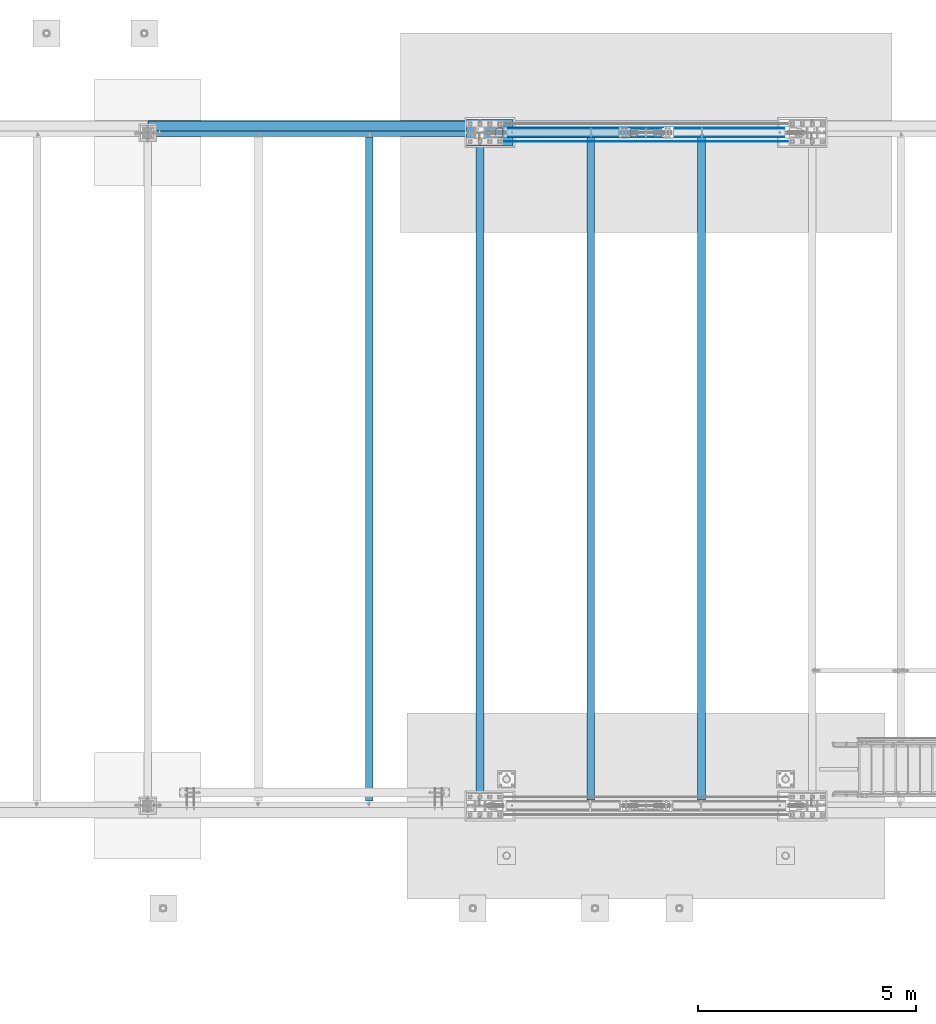
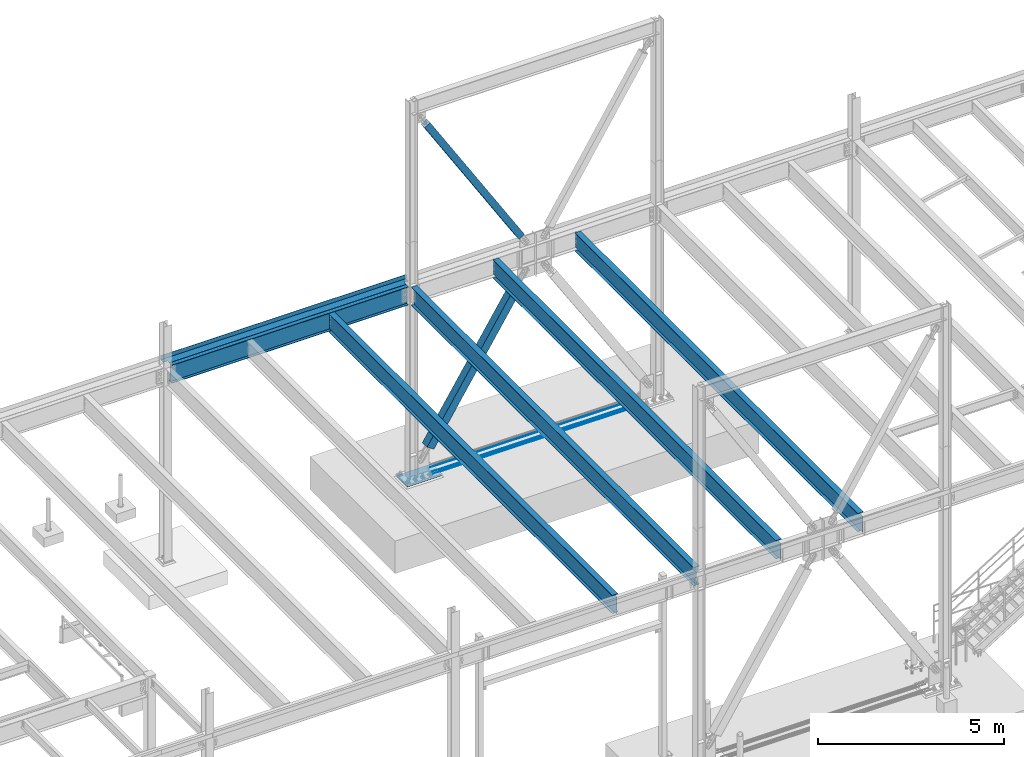
# One storey, part 1932 of 3843: 10 beams, 2 members, 11 elements without a shape of their own.
"""IFC2X3 building model written with IfcOpenShell, lengths in millimetres."""

from ifc_helpers import new_model, si_unit, frame, origin_with_axes, place, context, subcontext, project, spatial, faceted_brep, material, type_object, element, aggregate, save


model = new_model("IFC2X3")

# Units and contexts
model_context = context("Model", 3, precision=1e-05, world=origin_with_axes())
body_context = subcontext(model_context, "Body", "Model", "MODEL_VIEW")
ifc_project = project(units=[si_unit("LENGTHUNIT", "METRE", prefix="MILLI"), si_unit("AREAUNIT", "SQUARE_METRE"), si_unit("VOLUMEUNIT", "CUBIC_METRE"), si_unit("MASSUNIT", "GRAM", prefix="KILO"), si_unit("TIMEUNIT", "SECOND"), si_unit("PLANEANGLEUNIT", "RADIAN"), si_unit("SOLIDANGLEUNIT", "STERADIAN"), si_unit("THERMODYNAMICTEMPERATUREUNIT", "DEGREE_CELSIUS"), si_unit("LUMINOUSINTENSITYUNIT", "LUMEN")], contexts=[model_context])

# Site, building, storey
site_placement = place(None, origin_with_axes())
site = spatial("IfcSite", under=ifc_project, at=site_placement, CompositionType="ELEMENT")
building_placement = place(site_placement, origin_with_axes())
building = spatial("IfcBuilding", under=site, at=building_placement, Name="Undefined", CompositionType="ELEMENT")
storey_placement = place(building_placement, origin_with_axes())
storey = spatial("IfcBuildingStorey", under=building, at=storey_placement, Name="Undefined", CompositionType="ELEMENT", Elevation=0.0)

# Assembly, beam
assembly_1_placement = place(storey_placement, origin_with_axes())
assembly_1 = element("IfcElementAssembly", 1, at=assembly_1_placement, inside=storey, Name="REBAR", AssemblyPlace="NOTDEFINED", PredefinedType="RIGID_FRAME")
ifc_material_1 = material(Name="STEEL/A706-60")
beam_type_1 = type_object("IfcBeamType", Name="#10 REBAR", PredefinedType="NOTDEFINED")
beam_1_placement = place(assembly_1_placement, frame((23418.7999804674, 104355.9, 30132.3375), z_axis=(0.0, 0.0, 1.0), x_axis=(1.0, 0.0, 0.0)))
beam_1 = element("IfcBeam", 2, at=beam_1_placement, type_object=beam_type_1, material=ifc_material_1, Name="REBAR", ObjectType="#10 REBAR", context=body_context, shape_type="Brep", body=[
    faceted_brep([(0.0, -7.9375, 0.0), (0.0, -5.61266007566883, -5.61266007566883), (6502.48749999408, -5.61266007566883, -5.61266007566883), (6502.48749999408, -7.9375, 0.0), (0.0, 0.0, -7.9375), (6502.48749999408, 0.0, -7.9375), (0.0, 5.61266007566883, -5.61266007566883), (6502.48749999408, 5.61266007566883, -5.61266007566883), (0.0, 7.9375, 0.0), (6502.48749999408, 7.9375, 0.0), (0.0, 5.61266007566883, 5.61266007566883), (6502.48749999408, 5.61266007566883, 5.61266007566883), (0.0, 0.0, 7.9375), (6502.48749999408, 0.0, 7.9375), (0.0, -5.61266007566883, 5.61266007566883), (6502.48749999408, -5.61266007566883, 5.61266007566883)], [[[0, 1, 2, 3]], [[1, 4, 5, 2]], [[4, 6, 7, 5]], [[6, 8, 9, 7]], [[8, 10, 11, 9]], [[10, 12, 13, 11]], [[12, 14, 15, 13]], [[14, 0, 3, 15]], [[5, 7, 9, 11, 13, 15, 3, 2]], [[14, 12, 10, 8, 6, 4, 1, 0]]]),
])
aggregate(assembly_1, [beam_1])

assembly_2_placement = place(storey_placement, origin_with_axes())
assembly_2 = element("IfcElementAssembly", 3, at=assembly_2_placement, inside=storey, Name="REBAR", AssemblyPlace="NOTDEFINED", PredefinedType="RIGID_FRAME")
beam_2_placement = place(assembly_2_placement, frame((23418.7999804674, 104457.5, 30132.3375), z_axis=(0.0, 0.0, 1.0), x_axis=(1.0, 0.0, 0.0)))
beam_2 = element("IfcBeam", 4, at=beam_2_placement, type_object=beam_type_1, material=ifc_material_1, Name="REBAR", ObjectType="#10 REBAR", context=body_context, shape_type="Brep", body=[
    faceted_brep([(0.0, -7.9375, 0.0), (0.0, -5.61266007566883, -5.61266007566883), (6502.48749999408, -5.61266007566883, -5.61266007566883), (6502.48749999408, -7.9375, 0.0), (0.0, 0.0, -7.9375), (6502.48749999408, 0.0, -7.9375), (0.0, 5.61266007566883, -5.61266007566883), (6502.48749999408, 5.61266007566883, -5.61266007566883), (0.0, 7.9375, 0.0), (6502.48749999408, 7.9375, 0.0), (0.0, 5.61266007566883, 5.61266007566883), (6502.48749999408, 5.61266007566883, 5.61266007566883), (0.0, 0.0, 7.9375), (6502.48749999408, 0.0, 7.9375), (0.0, -5.61266007566883, 5.61266007566883), (6502.48749999408, -5.61266007566883, 5.61266007566883)], [[[0, 1, 2, 3]], [[1, 4, 5, 2]], [[4, 6, 7, 5]], [[6, 8, 9, 7]], [[8, 10, 11, 9]], [[10, 12, 13, 11]], [[12, 14, 15, 13]], [[14, 0, 3, 15]], [[5, 7, 9, 11, 13, 15, 3, 2]], [[14, 12, 10, 8, 6, 4, 1, 0]]]),
])
aggregate(assembly_2, [beam_2])

assembly_3_placement = place(storey_placement, origin_with_axes())
assembly_3 = element("IfcElementAssembly", 5, at=assembly_3_placement, inside=storey, Name="REBAR", AssemblyPlace="NOTDEFINED", PredefinedType="RIGID_FRAME")
beam_3_placement = place(assembly_3_placement, frame((23418.7999804674, 104660.7, 30132.3375), z_axis=(0.0, 0.0, 1.0), x_axis=(1.0, 0.0, 0.0)))
beam_3 = element("IfcBeam", 6, at=beam_3_placement, type_object=beam_type_1, material=ifc_material_1, Name="REBAR", ObjectType="#10 REBAR", context=body_context, shape_type="Brep", body=[
    faceted_brep([(0.0, -7.9375, 0.0), (0.0, -5.61266007566883, -5.61266007566883), (6502.48749999408, -5.61266007566883, -5.61266007566883), (6502.48749999408, -7.9375, 0.0), (0.0, 0.0, -7.9375), (6502.48749999408, 0.0, -7.9375), (0.0, 5.61266007566883, -5.61266007566883), (6502.48749999408, 5.61266007566883, -5.61266007566883), (0.0, 7.9375, 0.0), (6502.48749999408, 7.9375, 0.0), (0.0, 5.61266007566883, 5.61266007566883), (6502.48749999408, 5.61266007566883, 5.61266007566883), (0.0, 0.0, 7.9375), (6502.48749999408, 0.0, 7.9375), (0.0, -5.61266007566883, 5.61266007566883), (6502.48749999408, -5.61266007566883, 5.61266007566883)], [[[0, 1, 2, 3]], [[1, 4, 5, 2]], [[4, 6, 7, 5]], [[6, 8, 9, 7]], [[8, 10, 11, 9]], [[10, 12, 13, 11]], [[12, 14, 15, 13]], [[14, 0, 3, 15]], [[5, 7, 9, 11, 13, 15, 3, 2]], [[14, 12, 10, 8, 6, 4, 1, 0]]]),
])
aggregate(assembly_3, [beam_3])

# Assembly, member
assembly_4_placement = place(storey_placement, origin_with_axes())
assembly_4 = element("IfcElementAssembly", 7, at=assembly_4_placement, inside=storey, Name="None", AssemblyPlace="NOTDEFINED", PredefinedType="RIGID_FRAME")
ifc_material_2 = material(Name="STEEL/A992")
member_type_1 = type_object("IfcMemberType", Name="HSS8X8X3/16", PredefinedType="NOTDEFINED")
member_1_placement = place(assembly_4_placement, frame((26220.958940922, 104559.1, 36853.7019844734), z_axis=(0.0, 1.0, 0.0), x_axis=(-0.529701323009257, 0.0, 0.848184242014813)))
member_1 = element("IfcMember", 8, at=member_1_placement, type_object=member_type_1, material=ifc_material_2, Name="None", ObjectType="HSS8X8X3/16", context=body_context, shape_type="Brep", body=[
    faceted_brep([(2.03726813197136e-10, 96.8375000003298, -96.8374999999942), (-2.18278728425503e-10, -96.837500000317, -96.8374999999942), (5518.14999998289, -96.8375000060396, -96.8374999999942), (5518.14999998332, 96.8374999946072, -96.8374999999942), (-2.18278728425503e-10, -96.837500000317, 96.8374999999942), (5518.14999998289, -96.8375000060396, 96.8374999999942), (2.03726813197136e-10, 96.8375000003298, 96.8374999999942), (5518.14999998332, 96.8374999946072, 96.8374999999942), (2.18278728425503e-10, 101.600000000345, -101.600000000006), (2.18278728425503e-10, 101.600000000345, 101.600000000006), (5518.14999998333, 101.599999994626, 101.600000000006), (5518.14999998333, 101.599999994626, -101.600000000006), (-2.25554686039686e-10, -101.600000000329, 101.600000000006), (5518.14999998289, -101.600000006059, 101.600000000006), (-2.25554686039686e-10, -101.600000000329, -101.600000000006), (5518.14999998289, -101.600000006059, -101.600000000006)], [[[0, 1, 2, 3]], [[1, 4, 5, 2]], [[4, 6, 7, 5]], [[6, 0, 3, 7]], [[8, 9, 10, 11]], [[9, 12, 13, 10]], [[12, 14, 15, 13]], [[14, 8, 11, 15]], [[13, 15, 11, 10], [5, 7, 3, 2]], [[14, 12, 9, 8], [6, 4, 1, 0]]]),
])
aggregate(assembly_4, [member_1])

assembly_5_placement = place(storey_placement, origin_with_axes())
assembly_5 = element("IfcElementAssembly", 9, at=assembly_5_placement, inside=storey, Name="None", AssemblyPlace="NOTDEFINED", PredefinedType="RIGID_FRAME")
member_type_2 = type_object("IfcMemberType", Name="HSS10X10X1/4", PredefinedType="NOTDEFINED")
member_2_placement = place(assembly_5_placement, frame((23376.770306377, 104559.1, 30939.605175297), z_axis=(0.0, -1.0, 0.0), x_axis=(0.535402318785024, 0.0, 0.844597156660866)))
member_2 = element("IfcMember", 10, at=member_2_placement, type_object=member_type_2, material=ifc_material_2, Name="None", ObjectType="HSS10X10X1/4", context=body_context, shape_type="Brep", body=[
    faceted_brep([(2.00088834390044e-10, 120.650000000089, -120.649999999994), (-2.03726813197136e-10, -120.650000000081, -120.649999999994), (5175.25000000853, -120.650000001752, -120.649999999994), (5175.25000000861, 120.649999998298, -120.649999999994), (-2.03726813197136e-10, -120.650000000081, 120.649999999994), (5175.25000000853, -120.650000001752, 120.649999999994), (2.00088834390044e-10, 120.650000000089, 120.649999999994), (5175.25000000861, 120.649999998298, 120.649999999994), (2.16459739021957e-10, 127.000000000087, -127.0), (2.16459739021957e-10, 127.000000000087, 127.0), (5175.25000000861, 126.9999999983, 127.0), (5175.25000000861, 126.9999999983, -127.0), (-2.14640749618411e-10, -127.00000000008, 127.0), (5175.25000000852, -127.000000001754, 127.0), (-2.14640749618411e-10, -127.00000000008, -127.0), (5175.25000000852, -127.000000001754, -127.0)], [[[0, 1, 2, 3]], [[1, 4, 5, 2]], [[4, 6, 7, 5]], [[6, 0, 3, 7]], [[8, 9, 10, 11]], [[9, 12, 13, 10]], [[12, 14, 15, 13]], [[14, 8, 11, 15]], [[13, 15, 11, 10], [5, 7, 3, 2]], [[14, 12, 9, 8], [6, 4, 1, 0]]]),
])
aggregate(assembly_5, [member_2])

# Assembly, beam
assembly_6_placement = place(storey_placement, origin_with_axes())
assembly_6 = element("IfcElementAssembly", 11, at=assembly_6_placement, inside=storey, Name="BEAM", AssemblyPlace="NOTDEFINED", PredefinedType="RIGID_FRAME")
ifc_material_3 = material(Name="STEEL/A36")
beam_type_2 = type_object("IfcBeamType", PredefinedType="NOTDEFINED")
beam_4_placement = place(assembly_6_placement, frame((19050.0, 104597.2, 36439.475), z_axis=(-1.0, 0.0, 0.0), x_axis=(0.0, 1.0, 0.0)))
beam_4 = element("IfcBeam", 12, at=beam_4_placement, type_object=beam_type_2, material=ifc_material_3, Name="BENT_PLATE", context=body_context, shape_type="Brep", body=[
    faceted_brep([(101.599996948149, -3.17499999999563, 3670.30000000001), (101.599996948149, 3.17500000000291, 3670.30000000001), (0.0, 3.17500000000291, 3670.30000000001), (0.0, -3.17500000000291, 3670.30000000001), (101.599996948149, -3.17499999999563, 3806.825), (101.599996948149, 3.17500000000291, 3806.825), (0.0, -3.17500000000291, -3667.12500305074), (0.0, 3.17500000000291, -3667.12500305074), (103.187506103422, 3.17500000000291, -3667.12500305074), (103.187506103422, -3.17499999999563, -3667.12500305074), (103.187506103422, 3.17500000000291, -3806.825), (103.187506103422, -3.17499999999563, -3806.825), (241.300003051641, 3.17500000001019, -3806.825), (241.300003051685, -136.524996948348, -3806.825), (234.950003051679, -136.524996948348, -3806.825), (234.950003051636, -3.17499999999563, -3806.825), (241.300003051641, 3.17500000001019, 3806.825), (241.300003051685, -136.524996948348, 3806.825), (234.950003051679, -136.524996948348, 3806.825), (234.950003051636, -3.17499999999563, 3806.825)], [[[0, 1, 2, 3]], [[4, 5, 1, 0]], [[6, 7, 8, 9]], [[9, 8, 10, 11]], [[12, 13, 14, 15, 11, 10]], [[12, 16, 17, 13]], [[18, 14, 13, 17]], [[19, 15, 14, 18]], [[3, 6, 9, 11, 15, 19, 4, 0]], [[7, 6, 3, 2]], [[16, 12, 10, 8, 7, 2, 1, 5]], [[19, 18, 17, 16, 5, 4]]]),
])

assembly_7_placement = place(storey_placement, origin_with_axes())
assembly_7 = element("IfcElementAssembly", 13, at=assembly_7_placement, inside=storey, Name="BEAM", AssemblyPlace="NOTDEFINED", PredefinedType="RIGID_FRAME")
beam_type_3 = type_object("IfcBeamType", Name="W24X55", PredefinedType="NOTDEFINED")
beam_5_placement = place(assembly_7_placement, frame((20320.0, 89115.9, 36136.2625), z_axis=(0.0, 0.0, 1.0), x_axis=(0.0, 1.0, 0.0)))
beam_5 = element("IfcBeam", 14, at=beam_5_placement, type_object=beam_type_3, material=ifc_material_2, Name="BEAM", ObjectType="W24X55", context=body_context, shape_type="Brep", body=[
    faceted_brep([(17.4624999999942, -4.76250000000073, -274.637500000004), (17.4624999999942, 4.76250000000073, -274.637500000004), (93.6625001907232, 4.76250000000073, -274.637500000004), (93.6625001907232, -4.76250000000073, -274.637500000004), (98.5225797087624, 4.76250000000073, -275.604229922596), (98.5225797087624, -4.76250000000073, -275.604229922596), (102.642756176923, 4.76250000000073, -278.357243823069), (102.642756176923, -4.76250000000073, -278.357243823069), (105.395770077404, 4.76250000000073, -282.477420291223), (105.395770077404, -4.76250000000073, -282.477420291223), (106.362499999988, 4.76250000000073, -287.337500000001), (106.362499999988, -4.76250000000073, -287.337500000001), (106.362499999988, -88.8999999999996, -287.33749980927), (106.362499999988, 88.8999999999996, -287.337500000001), (106.362499999988, 88.8999999999996, -300.037499999999), (106.362499999988, -88.8999999999996, -300.037499809485), (15341.6, -88.8999999999996, -300.037499999999), (15341.6, 88.8999999999996, -300.037499999999), (15341.6, 88.8999999999996, -287.597499809272), (15341.6, -88.8999999999996, -287.597499809272), (15341.6, 88.8999999999996, 287.337500000001), (15341.6, 4.76250000000073, 287.337500000001), (106.362499999988, 4.76250000000073, 287.337500000001), (106.362499999988, 88.8999999999996, 287.337500000001), (93.6625001907232, -4.76250000000073, 274.637499999997), (93.6625001907232, 4.76250000000073, 274.637499999997), (17.4624999999942, 4.76250000000073, 274.637499999997), (17.4624999999942, -4.76250000000073, 274.637499999997), (98.5225797087624, -4.76250000000073, 275.604229922588), (98.5225797087624, 4.76250000000073, 275.604229922588), (102.642756176923, -4.76250000000073, 278.357243823062), (102.642756176923, 4.76250000000073, 278.357243823062), (105.395770077404, -4.76250000000073, 282.477420291216), (105.395770077404, 4.76250000000073, 282.477420291216), (106.362499999988, -4.76250000000073, 287.337500000001), (15341.6, -88.8999999999996, 300.037499999999), (15341.6, 88.8999999999996, 300.037499999999), (106.362499999988, 88.8999999999996, 300.037499999999), (106.362499999988, -88.8999999999996, 300.037499809485), (15341.6, -88.8999999999996, 287.337500000001), (106.362499999988, -88.8999999999996, 287.337500000001), (15341.6, -4.76250000000073, 287.337500000001), (15341.6, -4.76250000000073, 287.07749980926), (15341.6, 4.76250000000073, 287.07749980926), (15342.5667299226, -4.76250000000073, 282.217420291214), (15342.5667299226, 4.76250000000073, 282.217420291214), (15345.3197438231, -4.76250000000073, 278.09724382306), (15345.3197438231, 4.76250000000073, 278.09724382306), (15349.4399202912, -4.76250000000073, 275.344229922586), (15349.4399202912, 4.76250000000073, 275.344229922586), (15354.2999998093, -4.76250000000073, 274.377499999995), (15354.2999998093, 4.76250000000073, 274.377499999995), (15425.7375, -4.76250000000073, 274.377499999995), (15425.7375, 4.76250000000073, 274.377499999995), (15425.7375, -4.76250000000073, -274.897500000006), (15425.7375, 4.76250000000073, -274.897500000006), (15354.2999998093, -4.76250000000073, -274.897500000006), (15354.2999998093, 4.76250000000073, -274.897500000006), (15349.4399202912, -4.76250000000073, -275.864229922598), (15349.4399202912, 4.76250000000073, -275.864229922598), (15345.3197438231, -4.76250000000073, -278.617243823071), (15345.3197438231, 4.76250000000073, -278.617243823071), (15342.5667299226, -4.76250000000073, -282.737420291225), (15342.5667299226, 4.76250000000073, -282.737420291225), (15341.6517171776, -4.76250000000073, -287.337500000001), (15341.6517171776, -88.8999999999996, -287.337500000001), (15341.6517171776, 88.8999999999996, -287.337500000001), (15341.6517171776, 4.76250000000073, -287.337500000001), (17.4624999999942, 4.76250000000073, -197.262499999997), (17.4624999999942, 4.76250000000073, 261.9375)], [[[0, 1, 2, 3]], [[3, 2, 4, 5]], [[5, 4, 6, 7]], [[7, 6, 8, 9]], [[9, 8, 10, 11]], [[12, 11, 10, 13, 14, 15]], [[16, 17, 18, 19]], [[20, 21, 22, 23]], [[24, 25, 26, 27]], [[28, 29, 25, 24]], [[30, 31, 29, 28]], [[32, 33, 31, 30]], [[34, 22, 33, 32]], [[35, 36, 37, 38]], [[39, 35, 38, 40]], [[41, 39, 40, 34]], [[38, 37, 23, 22, 34, 40]], [[36, 20, 23, 37]], [[35, 39, 41, 42, 43, 21, 20, 36]], [[44, 45, 43, 42]], [[46, 47, 45, 44]], [[48, 49, 47, 46]], [[50, 51, 49, 48]], [[52, 53, 51, 50]], [[53, 52, 54, 55]], [[54, 56, 57, 55]], [[58, 59, 57, 56]], [[60, 61, 59, 58]], [[62, 63, 61, 60]], [[64, 65, 19, 18, 66, 67, 63, 62]], [[16, 19, 65, 12, 15]], [[17, 16, 15, 14]], [[66, 18, 17, 14, 13]], [[67, 66, 13, 10]], [[6, 4, 2, 1, 68, 69, 26, 25, 29, 31, 33, 22, 21, 43, 45, 47, 49, 51, 53, 55, 57, 59, 61, 63, 67, 10, 8]], [[27, 26, 69, 68, 1, 0]], [[64, 62, 60, 58, 56, 54, 52, 50, 48, 46, 44, 42, 41, 34, 32, 30, 28, 24, 27, 0, 3, 5, 7, 9, 11]], [[65, 64, 11, 12]]]),
])
aggregate(assembly_7, [beam_5])

# Beam
beam_6_placement = place(assembly_6_placement, frame((15240.0, 104559.1, 36136.2625), z_axis=(0.0, 0.0, 1.0), x_axis=(1.0, 0.0, 0.0)))
beam_6 = element("IfcBeam", 15, at=beam_6_placement, type_object=beam_type_3, material=ifc_material_2, Name="BEAM", ObjectType="W24X55", context=body_context, shape_type="Brep", body=[
    faceted_brep([(139.699999999997, -88.8999999999996, -300.037499999999), (139.699999999997, 88.8999999999996, -300.037499999999), (7477.125, 88.8999999999942, -300.037499999999), (7477.125, -88.8999999999942, -300.037499999999), (139.699999999997, -88.8999999999996, -287.337500000001), (139.699999999997, -4.76250000000073, -287.337500000001), (139.7, -4.76249999999709, -208.702493896482), (139.7, -4.76249999999709, 262.677499999998), (139.699999999997, -4.76250000000073, 287.337500000001), (139.699999999997, -88.8999999999996, 287.337500000001), (139.699999999997, -88.8999999999996, 300.037499999999), (139.699999999997, 88.8999999999996, 300.037499999999), (139.699999999997, 88.8999999999996, 287.337500000001), (139.699999999997, 4.76250000000073, 287.337500000001), (139.699999999997, 4.76250000000073, -287.337500000001), (139.699999999997, 88.8999999999996, -287.337500000001), (7477.125, -88.8999999999942, -287.337500000001), (7477.125, -4.76249999999709, -287.337500000001), (7477.125, -4.76249999999709, 287.337500000001), (7477.125, -88.8999999999942, 287.337500000001), (7477.125, -88.8999999999942, 300.037499999999), (7477.125, 88.8999999999942, 300.037499999999), (7477.125, 88.8999999999942, 287.337500000001), (7477.125, 4.76249999999709, 287.337500000001), (7477.125, 4.76249999999709, -287.337500000001), (7477.125, 88.8999999999942, -287.337500000001)], [[[0, 1, 2, 3]], [[0, 4, 5, 6, 7, 8, 9, 10, 11, 12, 13, 14, 15, 1]], [[5, 4, 16, 17]], [[8, 7, 6, 5, 17, 18]], [[9, 8, 18, 19]], [[10, 9, 19, 20]], [[11, 10, 20, 21]], [[12, 11, 21, 22]], [[13, 12, 22, 23]], [[14, 13, 23, 24]], [[15, 14, 24, 25]], [[1, 15, 25, 2]], [[24, 23, 22, 21, 20, 19, 18, 17, 16, 3, 2, 25]], [[4, 0, 3, 16]]]),
])

aggregate(assembly_6, [beam_4, beam_6])

# Assembly, beam
assembly_8_placement = place(storey_placement, origin_with_axes())
assembly_8 = element("IfcElementAssembly", 16, at=assembly_8_placement, inside=storey, Name="BEAM", AssemblyPlace="NOTDEFINED", PredefinedType="RIGID_FRAME")
beam_7_placement = place(assembly_8_placement, frame((25400.0, 89115.9, 36136.2625), z_axis=(0.0, 0.0, 1.0), x_axis=(0.0, 1.0, 0.0)))
beam_7 = element("IfcBeam", 17, at=beam_7_placement, type_object=beam_type_3, material=ifc_material_2, Name="BEAM", ObjectType="W24X55", context=body_context, shape_type="Brep", body=[
    faceted_brep([(18.2562500000058, -4.76250000000073, -274.637499999997), (18.2562500000058, 4.76250000000073, -274.637499999997), (119.856250190758, 4.76250000000073, -274.637499999997), (119.856250190758, -4.76250000000073, -274.637499999997), (124.716329708797, 4.76250000000073, -275.604229922588), (124.716329708797, -4.76250000000073, -275.604229922588), (128.836506176958, 4.76250000000073, -278.357243823062), (128.836506176958, -4.76250000000073, -278.357243823062), (131.589520077439, 4.76250000000073, -282.477420291216), (131.589520077439, -4.76250000000073, -282.477420291216), (132.556250000023, 4.76250000000073, -287.337500000001), (132.556250000023, -4.76250000000073, -287.337500000001), (132.556250000023, -88.9000000000015, -287.337499809262), (132.556250000023, 88.9000000000015, -287.337500000001), (132.556250000023, 88.9000000000015, -300.037499999999), (132.556250000023, -88.9000000000015, -300.037499999999), (15315.40625, 88.9000000000015, 287.337500000001), (15315.40625, 4.76250000000073, 287.337500000001), (132.556250000023, 4.76250000000073, 287.337500000001), (132.556250000023, 88.9000000000015, 287.337500000001), (119.856250190758, -4.76250000000073, 261.9375), (119.856250190758, 4.76250000000073, 261.9375), (18.2562500000058, 4.76250000000073, 261.9375), (18.2562500000058, -4.76250000000073, 261.9375), (124.716329708797, -4.76250000000073, 262.904229922591), (124.716329708797, 4.76250000000073, 262.904229922591), (128.836506176958, -4.76250000000073, 265.657243823065), (128.836506176958, 4.76250000000073, 265.657243823065), (131.589520077439, -4.76250000000073, 269.777420291219), (131.589520077439, 4.76250000000073, 269.777420291219), (132.556250000023, -4.76250000000073, 274.637499809265), (132.556250000023, 4.76250000000073, 274.637499809265), (15315.40625, -88.9000000000015, 300.037499999999), (15315.40625, 88.9000000000015, 300.037499999999), (132.556250000023, 88.9000000000015, 300.037499999999), (132.556250000023, -88.9000000000015, 300.037499999999), (15315.40625, -88.9000000000015, 287.337500000001), (132.556250000023, -88.9000000000015, 287.337500000001), (15315.40625, -4.76250000000073, 287.337500000001), (132.556250000023, -4.76250000000073, 287.337500000001), (15315.40625, -4.76250000000073, 274.637499809265), (15315.40625, 4.76250000000073, 274.637499809265), (15316.3729799226, -4.76250000000073, 269.777420291219), (15316.3729799226, 4.76250000000073, 269.777420291219), (15319.1259938231, -4.76250000000073, 265.657243823065), (15319.1259938231, 4.76250000000073, 265.657243823065), (15323.2461702912, -4.76250000000073, 262.904229922591), (15323.2461702912, 4.76250000000073, 262.904229922591), (15328.1062498093, -4.76250000000073, 261.9375), (15328.1062498093, 4.76250000000073, 261.9375), (15424.94375, -4.76250000000073, 261.9375), (15424.94375, 4.76250000000073, 261.9375), (15424.94375, -4.76250000000073, -274.637499999997), (15424.94375, 4.76250000000073, -274.637499999997), (15328.1062498093, -4.76250000000073, -274.637499999997), (15328.1062498093, 4.76250000000073, -274.637499999997), (15323.2461702912, -4.76250000000073, -275.604229922581), (15323.2461702912, 4.76250000000073, -275.604229922581), (15319.1259938231, -4.76250000000073, -278.357243823062), (15319.1259938231, 4.76250000000073, -278.357243823062), (15316.3729799226, -4.76250000000073, -282.477420291216), (15316.3729799226, 4.76250000000073, -282.477420291216), (15315.40625, -4.76250000000073, -287.337500000001), (15315.40625, 4.76250000000073, -287.337500000001), (15315.40625, -88.9000000000015, -287.337500000001), (15315.40625, -88.9000000000015, -300.037499999999), (15315.40625, 88.9000000000015, -300.037499999999), (15315.40625, 88.9000000000015, -287.337500000001)], [[[0, 1, 2, 3]], [[3, 2, 4, 5]], [[5, 4, 6, 7]], [[7, 6, 8, 9]], [[9, 8, 10, 11]], [[12, 11, 10, 13, 14, 15]], [[16, 17, 18, 19]], [[20, 21, 22, 23]], [[24, 25, 21, 20]], [[26, 27, 25, 24]], [[28, 29, 27, 26]], [[30, 31, 29, 28]], [[32, 33, 34, 35]], [[36, 32, 35, 37]], [[38, 36, 37, 39]], [[35, 34, 19, 18, 31, 30, 39, 37]], [[33, 16, 19, 34]], [[32, 36, 38, 40, 41, 17, 16, 33]], [[42, 43, 41, 40]], [[44, 45, 43, 42]], [[46, 47, 45, 44]], [[48, 49, 47, 46]], [[50, 51, 49, 48]], [[51, 50, 52, 53]], [[52, 54, 55, 53]], [[56, 57, 55, 54]], [[58, 59, 57, 56]], [[60, 61, 59, 58]], [[62, 63, 61, 60]], [[64, 65, 66, 67, 63, 62]], [[65, 64, 12, 15]], [[66, 65, 15, 14]], [[67, 66, 14, 13]], [[63, 67, 13, 10]], [[6, 4, 2, 1, 22, 21, 25, 27, 29, 31, 18, 17, 41, 43, 45, 47, 49, 51, 53, 55, 57, 59, 61, 63, 10, 8]], [[23, 22, 1, 0]], [[62, 60, 58, 56, 54, 52, 50, 48, 46, 44, 42, 40, 38, 39, 30, 28, 26, 24, 20, 23, 0, 3, 5, 7, 9, 11]], [[64, 62, 11, 12]]]),
])
aggregate(assembly_8, [beam_7])

assembly_9_placement = place(storey_placement, origin_with_axes())
assembly_9 = element("IfcElementAssembly", 18, at=assembly_9_placement, inside=storey, Name="BEAM", AssemblyPlace="NOTDEFINED", PredefinedType="RIGID_FRAME")
beam_8_placement = place(assembly_9_placement, frame((27940.0, 89115.9, 36136.2625), z_axis=(0.0, 0.0, 1.0), x_axis=(0.0, 1.0, 0.0)))
beam_8 = element("IfcBeam", 19, at=beam_8_placement, type_object=beam_type_3, material=ifc_material_2, Name="BEAM", ObjectType="W24X55", context=body_context, shape_type="Brep", body=[
    faceted_brep([(18.2562500000058, -4.76250000000073, -274.637499999997), (18.2562500000058, 4.76250000000073, -274.637499999997), (119.856250190758, 4.76250000000073, -274.637499999997), (119.856250190758, -4.76250000000073, -274.637499999997), (124.716329708797, 4.76250000000073, -275.604229922588), (124.716329708797, -4.76250000000073, -275.604229922588), (128.836506176958, 4.76250000000073, -278.357243823062), (128.836506176958, -4.76250000000073, -278.357243823062), (131.589520077439, 4.76250000000073, -282.477420291216), (131.589520077439, -4.76250000000073, -282.477420291216), (132.556250000023, 4.76250000000073, -287.337500000001), (132.556250000023, -4.76250000000073, -287.337500000001), (132.556250000023, -88.9000000000015, -287.337499809262), (132.556250000023, 88.9000000000015, -287.337500000001), (132.556250000023, 88.9000000000015, -300.037499999999), (132.556250000023, -88.9000000000015, -300.037499999999), (15315.40625, 88.9000000000015, 287.337500000001), (15315.40625, 4.76250000000073, 287.337500000001), (132.556250000023, 4.76250000000073, 287.337500000001), (132.556250000023, 88.9000000000015, 287.337500000001), (119.856250190758, -4.76250000000073, 261.9375), (119.856250190758, 4.76250000000073, 261.9375), (18.2562500000058, 4.76250000000073, 261.9375), (18.2562500000058, -4.76250000000073, 261.9375), (124.716329708797, -4.76250000000073, 262.904229922591), (124.716329708797, 4.76250000000073, 262.904229922591), (128.836506176958, -4.76250000000073, 265.657243823065), (128.836506176958, 4.76250000000073, 265.657243823065), (131.589520077439, -4.76250000000073, 269.777420291219), (131.589520077439, 4.76250000000073, 269.777420291219), (132.556250000023, -4.76250000000073, 274.637499809265), (132.556250000023, 4.76250000000073, 274.637499809265), (15315.40625, -88.9000000000015, 300.037499999999), (15315.40625, 88.9000000000015, 300.037499999999), (132.556250000023, 88.9000000000015, 300.037499999999), (132.556250000023, -88.9000000000015, 300.037499999999), (15315.40625, -88.9000000000015, 287.337500000001), (132.556250000023, -88.9000000000015, 287.337500000001), (15315.40625, -4.76250000000073, 287.337500000001), (132.556250000023, -4.76250000000073, 287.337500000001), (15315.40625, -4.76250000000073, 274.637499809265), (15315.40625, 4.76250000000073, 274.637499809265), (15316.3729799226, -4.76250000000073, 269.777420291219), (15316.3729799226, 4.76250000000073, 269.777420291219), (15319.1259938231, -4.76250000000073, 265.657243823065), (15319.1259938231, 4.76250000000073, 265.657243823065), (15323.2461702912, -4.76250000000073, 262.904229922591), (15323.2461702912, 4.76250000000073, 262.904229922591), (15328.1062498093, -4.76250000000073, 261.9375), (15328.1062498093, 4.76250000000073, 261.9375), (15424.94375, -4.76250000000073, 261.9375), (15424.94375, 4.76250000000073, 261.9375), (15424.94375, -4.76250000000073, -274.637499999997), (15424.94375, 4.76250000000073, -274.637499999997), (15328.1062498093, -4.76250000000073, -274.637499999997), (15328.1062498093, 4.76250000000073, -274.637499999997), (15323.2461702912, -4.76250000000073, -275.604229922581), (15323.2461702912, 4.76250000000073, -275.604229922581), (15319.1259938231, -4.76250000000073, -278.357243823062), (15319.1259938231, 4.76250000000073, -278.357243823062), (15316.3729799226, -4.76250000000073, -282.477420291216), (15316.3729799226, 4.76250000000073, -282.477420291216), (15315.40625, -4.76250000000073, -287.337500000001), (15315.40625, 4.76250000000073, -287.337500000001), (15315.40625, -88.9000000000015, -287.337500000001), (15315.40625, -88.9000000000015, -300.037499999999), (15315.40625, 88.9000000000015, -300.037499999999), (15315.40625, 88.9000000000015, -287.337500000001)], [[[0, 1, 2, 3]], [[3, 2, 4, 5]], [[5, 4, 6, 7]], [[7, 6, 8, 9]], [[9, 8, 10, 11]], [[12, 11, 10, 13, 14, 15]], [[16, 17, 18, 19]], [[20, 21, 22, 23]], [[24, 25, 21, 20]], [[26, 27, 25, 24]], [[28, 29, 27, 26]], [[30, 31, 29, 28]], [[32, 33, 34, 35]], [[36, 32, 35, 37]], [[38, 36, 37, 39]], [[35, 34, 19, 18, 31, 30, 39, 37]], [[33, 16, 19, 34]], [[32, 36, 38, 40, 41, 17, 16, 33]], [[42, 43, 41, 40]], [[44, 45, 43, 42]], [[46, 47, 45, 44]], [[48, 49, 47, 46]], [[50, 51, 49, 48]], [[51, 50, 52, 53]], [[52, 54, 55, 53]], [[56, 57, 55, 54]], [[58, 59, 57, 56]], [[60, 61, 59, 58]], [[62, 63, 61, 60]], [[64, 65, 66, 67, 63, 62]], [[65, 64, 12, 15]], [[66, 65, 15, 14]], [[67, 66, 14, 13]], [[63, 67, 13, 10]], [[6, 4, 2, 1, 22, 21, 25, 27, 29, 31, 18, 17, 41, 43, 45, 47, 49, 51, 53, 55, 57, 59, 61, 63, 10, 8]], [[23, 22, 1, 0]], [[62, 60, 58, 56, 54, 52, 50, 48, 46, 44, 42, 40, 38, 39, 30, 28, 26, 24, 20, 23, 0, 3, 5, 7, 9, 11]], [[64, 62, 11, 12]]]),
])
aggregate(assembly_9, [beam_8])

assembly_10_placement = place(storey_placement, origin_with_axes())
assembly_10 = element("IfcElementAssembly", 20, at=assembly_10_placement, inside=storey, Name="BEAM", AssemblyPlace="NOTDEFINED", PredefinedType="RIGID_FRAME")
beam_9_placement = place(assembly_10_placement, frame((22860.0, 89115.9, 36136.2625), z_axis=(0.0, 0.0, 1.0), x_axis=(0.0, 1.0, 0.0)))
beam_9 = element("IfcBeam", 21, at=beam_9_placement, type_object=beam_type_3, material=ifc_material_2, Name="BEAM", ObjectType="W24X55", context=body_context, shape_type="Brep", body=[
    faceted_brep([(141.287499999991, -88.9000000000015, -300.037499999999), (141.287499999991, 88.9000000000015, -300.037499999999), (15301.9125, 88.9000000000015, -300.037499999999), (15301.9125, -88.9000000000015, -300.037499999999), (141.287499999991, -88.9000000000015, -287.337500000001), (141.287499999991, -4.76250000000073, -287.337500000001), (141.287499999991, -4.76250000000073, 287.337500000001), (141.287499999991, -88.9000000000015, 287.337500000001), (141.287499999991, -88.9000000000015, 300.037499999999), (141.287499999991, 88.9000000000015, 300.037499999999), (141.287499999991, 88.9000000000015, 287.337500000001), (141.287499999991, 4.76250000000073, 287.337500000001), (141.287499999991, 4.76250000000073, 262.677499999998), (141.287499999991, 4.76250000000073, -196.002512207029), (141.287499999991, 4.76250000000073, -287.337500000001), (141.287499999991, 88.9000000000015, -287.337500000001), (15301.9125, -88.9000000000015, -287.337500000001), (15301.9125, -4.76250000000073, -287.337500000001), (15301.9125, -4.76250000000073, 287.337500000001), (15301.9125, -88.9000000000015, 287.337500000001), (15301.9125, -88.9000000000015, 300.037499999999), (15301.9125, 88.9000000000015, 300.037499999999), (15301.9125, 88.9000000000015, 287.337500000001), (15301.9125, 4.76250000000073, 287.337500000001), (15301.9125, 4.76250000000073, 262.677499999998), (15301.9125, 4.76250000000073, -196.002512207029), (15301.9125, 4.76250000000073, -287.337500000001), (15301.9125, 88.9000000000015, -287.337500000001)], [[[0, 1, 2, 3]], [[0, 4, 5, 6, 7, 8, 9, 10, 11, 12, 13, 14, 15, 1]], [[5, 4, 16, 17]], [[6, 5, 17, 18]], [[7, 6, 18, 19]], [[8, 7, 19, 20]], [[9, 8, 20, 21]], [[10, 9, 21, 22]], [[11, 10, 22, 23]], [[14, 13, 12, 11, 23, 24, 25, 26]], [[15, 14, 26, 27]], [[1, 15, 27, 2]], [[26, 25, 24, 23, 22, 21, 20, 19, 18, 17, 16, 3, 2, 27]], [[4, 0, 3, 16]]]),
])
aggregate(assembly_10, [beam_9])

assembly_11_placement = place(storey_placement, origin_with_axes())
assembly_11 = element("IfcElementAssembly", 22, at=assembly_11_placement, inside=storey, Name="TEMPLATE", AssemblyPlace="NOTDEFINED", PredefinedType="RIGID_FRAME")
ifc_material_4 = material(Name="STEEL/A572-50")
beam_type_4 = type_object("IfcBeamType", PredefinedType="NOTDEFINED")
beam_10_placement = place(assembly_11_placement, frame((23622.0000061035, 104559.1, 30065.6625), z_axis=(0.0, -1.0, 0.0), x_axis=(-1.0, 0.0, 0.0)))
beam_10 = element("IfcBeam", 23, at=beam_10_placement, type_object=beam_type_4, material=ifc_material_4, Name="TEMPLATE", context=body_context, shape_type="Brep", body=[
    faceted_brep([(0.0, 4.76250000000073, -304.800000000003), (0.0, 4.76250000000073, 304.800000000003), (1066.80001220703, 4.76250000000073, 304.800000000003), (1066.80001220703, 4.76250000000073, -304.800000000003), (0.0, -4.76250000000073, 304.800000000003), (1066.80001220703, -4.76250000000073, 304.800000000003), (0.0, -4.76250000000073, -304.800000000003), (1066.80001220703, -4.76250000000073, -304.800000000003)], [[[0, 1, 2, 3]], [[1, 4, 5, 2]], [[4, 6, 7, 5]], [[6, 0, 3, 7]], [[5, 7, 3, 2]], [[6, 4, 1, 0]]]),
])
aggregate(assembly_11, [beam_10])

save(model, "model.ifc")
